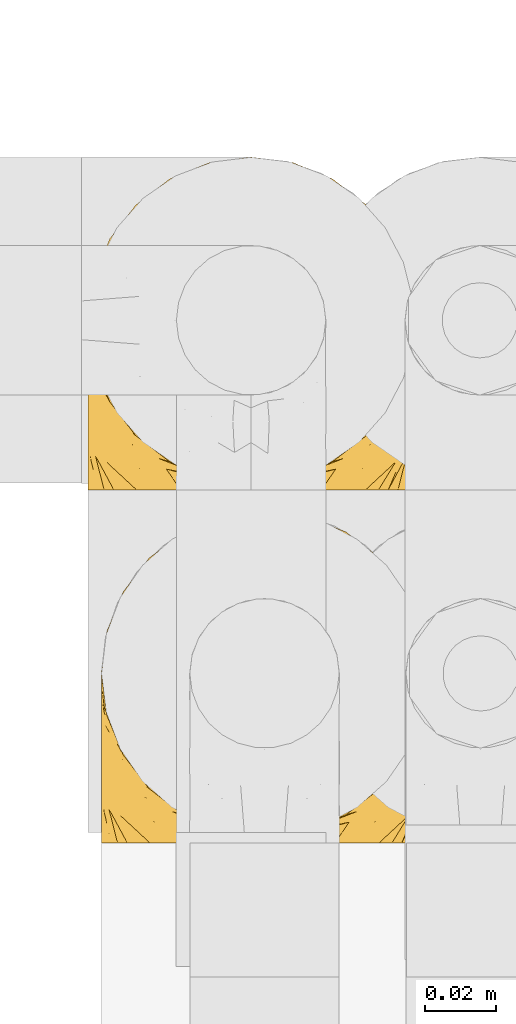
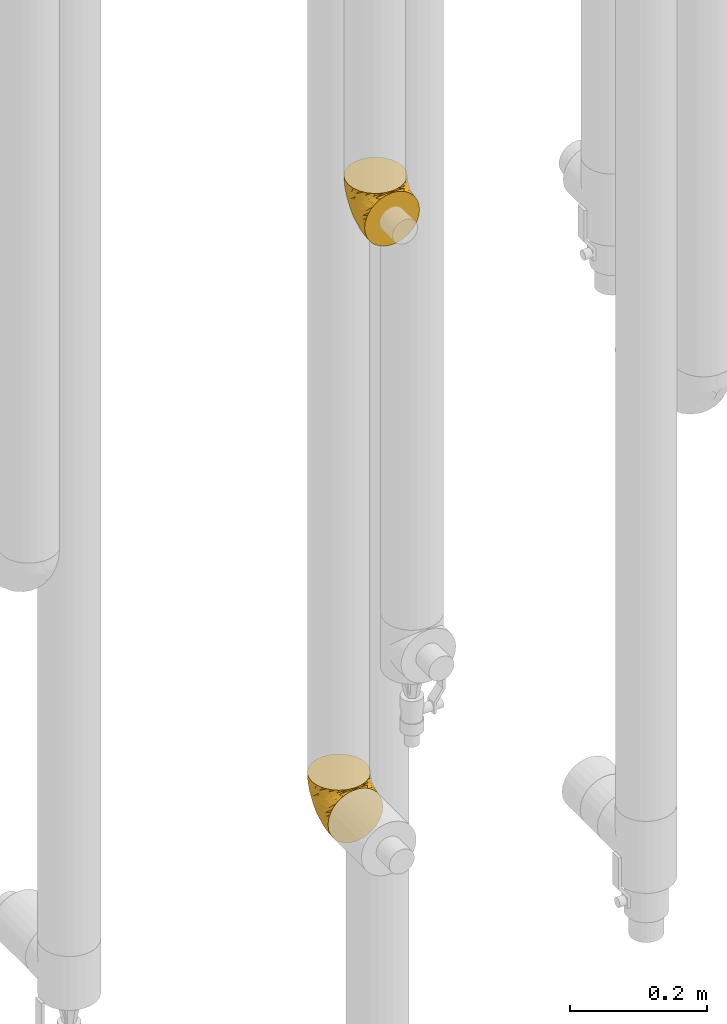
# One storey, part 240 of 827: 2 coverings.
"""IFC2X3 building model written with IfcOpenShell, lengths in millimetres."""

from ifc_helpers import new_model, entity, si_unit, converted_unit, derived_unit, direction, frame, origin, place, context, subcontext, project, spatial, faceted_brep, element, save


model = new_model("IFC2X3")

# Units and contexts
model_context = context("Model", 3, precision=0.01, world=origin(), true_north=direction((6.12303176911189e-17, 1.0)))
body_context = subcontext(model_context, "Body", "Model", "MODEL_VIEW")
ifc_project = project(units=[si_unit("LENGTHUNIT", "METRE", prefix="MILLI"), si_unit("AREAUNIT", "SQUARE_METRE"), si_unit("VOLUMEUNIT", "CUBIC_METRE"), converted_unit("PLANEANGLEUNIT", "DEGREE", entity("IfcRatioMeasure", 0.0174532925199433), si_unit("PLANEANGLEUNIT", "RADIAN"), dimensions=[0, 0, 0, 0, 0, 0, 0]), si_unit("MASSUNIT", "GRAM", prefix="KILO"), derived_unit("MASSDENSITYUNIT", [(si_unit("MASSUNIT", "GRAM", prefix="KILO"), 1), (si_unit("LENGTHUNIT", "METRE"), -3)]), derived_unit("MOMENTOFINERTIAUNIT", [(si_unit("LENGTHUNIT", "METRE"), 4)]), si_unit("TIMEUNIT", "SECOND"), si_unit("FREQUENCYUNIT", "HERTZ"), si_unit("THERMODYNAMICTEMPERATUREUNIT", "DEGREE_CELSIUS"), derived_unit("THERMALTRANSMITTANCEUNIT", [(si_unit("MASSUNIT", "GRAM", prefix="KILO"), 1), (si_unit("THERMODYNAMICTEMPERATUREUNIT", "KELVIN"), -1), (si_unit("TIMEUNIT", "SECOND"), -3)]), derived_unit("VOLUMETRICFLOWRATEUNIT", [(si_unit("LENGTHUNIT", "METRE"), 3), (si_unit("TIMEUNIT", "SECOND"), -1)]), derived_unit("MASSFLOWRATEUNIT", [(si_unit("MASSUNIT", "GRAM", prefix="KILO"), 1), (si_unit("TIMEUNIT", "SECOND"), -1)]), derived_unit("ROTATIONALFREQUENCYUNIT", [(si_unit("TIMEUNIT", "SECOND"), -1)]), si_unit("ELECTRICCURRENTUNIT", "AMPERE"), si_unit("ELECTRICVOLTAGEUNIT", "VOLT"), si_unit("POWERUNIT", "WATT"), si_unit("FORCEUNIT", "NEWTON", prefix="KILO"), si_unit("ILLUMINANCEUNIT", "LUX"), si_unit("LUMINOUSFLUXUNIT", "LUMEN"), si_unit("LUMINOUSINTENSITYUNIT", "CANDELA"), derived_unit("USERDEFINED", [(si_unit("MASSUNIT", "GRAM", prefix="KILO"), -1), (si_unit("LENGTHUNIT", "METRE"), -2), (si_unit("TIMEUNIT", "SECOND"), 3), (si_unit("LUMINOUSFLUXUNIT", "LUMEN"), 1)]), derived_unit("LINEARVELOCITYUNIT", [(si_unit("LENGTHUNIT", "METRE"), 1), (si_unit("TIMEUNIT", "SECOND"), -1)]), si_unit("PRESSUREUNIT", "PASCAL"), derived_unit("USERDEFINED", [(si_unit("LENGTHUNIT", "METRE"), -2), (si_unit("MASSUNIT", "GRAM", prefix="KILO"), 1), (si_unit("TIMEUNIT", "SECOND"), -2)]), derived_unit("LINEARFORCEUNIT", [(si_unit("MASSUNIT", "GRAM", prefix="KILO"), 1), (si_unit("LENGTHUNIT", "METRE"), 1), (si_unit("TIMEUNIT", "SECOND"), -2), (si_unit("LENGTHUNIT", "METRE"), -1)]), derived_unit("PLANARFORCEUNIT", [(si_unit("MASSUNIT", "GRAM", prefix="KILO"), 1), (si_unit("LENGTHUNIT", "METRE"), 1), (si_unit("TIMEUNIT", "SECOND"), -2), (si_unit("LENGTHUNIT", "METRE"), -2)])], contexts=[model_context])

# Site, building, storey
site_placement = place(None, origin())
site = spatial("IfcSite", under=ifc_project, at=site_placement, CompositionType="ELEMENT")
building_placement = place(site_placement, origin())
building = spatial("IfcBuilding", under=site, at=building_placement, CompositionType="ELEMENT")
storey_placement = place(building_placement, frame((0.0, 0.0, 28200.0)))
storey = spatial("IfcBuildingStorey", under=building, at=storey_placement, Name="08", CompositionType="ELEMENT", Elevation=28200.0)

# Coverings
covering_1_placement = place(storey_placement, frame((30622.54, 14866.61, 2202.65)))
element("IfcCovering", 1, at=covering_1_placement, inside=storey, Name=":ADSK_", ObjectType=":ADSK_", PredefinedType="INSULATION", context=body_context, shape_type="Brep", body=[
    faceted_brep([(11.68, 1.6, 18.98), (19.0, 1.6, 11.67), (27.76, 1.6, 6.17), (37.52, 1.6, 2.75), (47.8, 1.6, 1.6), (58.08, 1.6, 2.75), (67.85, 1.6, 6.17), (76.61, 1.6, 11.68), (83.92, 1.6, 19.0), (89.42, 1.6, 27.76), (92.84, 1.6, 37.52), (94.0, 1.6, 47.8), (93.53, 1.6, 51.94), (93.18, 1.6, 55.01), (92.84, 1.6, 58.08), (91.13, 1.6, 62.96), (89.42, 1.6, 67.85), (86.66, 1.6, 72.23), (83.91, 1.6, 76.61), (80.25, 1.6, 80.26), (76.59, 1.6, 83.92), (67.83, 1.6, 89.42), (62.95, 1.6, 91.13), (58.07, 1.6, 92.84), (47.8, 1.6, 94.0), (37.51, 1.6, 92.84), (32.63, 1.6, 91.13), (27.74, 1.6, 89.42), (18.98, 1.6, 83.91), (15.33, 1.6, 80.25), (11.67, 1.6, 76.59), (8.92, 1.6, 72.21), (6.17, 1.6, 67.83), (4.46, 1.6, 62.95), (2.75, 1.6, 58.07), (2.41, 1.6, 55.0), (2.06, 1.6, 51.94), (1.6, 1.6, 47.8), (2.75, 1.6, 37.51), (6.17, 1.6, 27.74), (47.8, 3.4, 95.8), (59.75, 4.97, 95.8), (70.9, 9.58, 95.8), (75.68, 13.26, 95.8), (80.46, 16.93, 95.8), (84.13, 21.71, 95.8), (87.81, 26.5, 95.8), (90.11, 32.07, 95.8), (92.42, 37.64, 95.8), (92.9, 41.25, 95.8), (93.17, 43.34, 95.8), (93.45, 45.42, 95.8), (94.0, 49.6, 95.8), (92.42, 61.55, 95.8), (87.81, 72.7, 95.8), (80.46, 82.26, 95.8), (70.9, 89.61, 95.8), (59.75, 94.22, 95.8), (47.8, 95.8, 95.8), (35.84, 94.22, 95.8), (24.7, 89.61, 95.8), (15.13, 82.26, 95.8), (7.78, 72.7, 95.8), (3.17, 61.55, 95.8), (1.6, 49.6, 95.8), (2.14, 45.42, 95.8), (2.69, 41.25, 95.8), (3.17, 37.64, 95.8), (5.48, 32.07, 95.8), (7.78, 26.5, 95.8), (11.46, 21.71, 95.8), (15.13, 16.93, 95.8), (19.91, 13.26, 95.8), (24.7, 9.58, 95.8), (35.84, 4.97, 95.8), (23.61, 81.55, 60.58), (31.99, 90.4, 74.11), (35.87, 83.0, 51.59), (47.8, 91.18, 66.69), (40.43, 93.13, 76.19), (47.8, 94.0, 84.43), (31.83, 66.19, 31.2), (23.37, 70.92, 42.88), (21.41, 85.95, 79.41), (3.07, 49.74, 60.7), (1.6, 35.54, 61.85), (1.6, 38.14, 65.75), (1.6, 40.74, 69.64), (1.6, 43.34, 73.53), (1.6, 45.94, 77.43), (13.45, 77.59, 74.59), (15.25, 71.17, 54.72), (8.07, 65.81, 64.18), (16.0, 59.03, 37.94), (17.34, 45.85, 25.89), (10.58, 45.79, 34.73), (5.34, 41.42, 42.89), (2.39, 34.51, 49.83), (8.36, 56.04, 48.58), (10.04, 15.15, 22.41), (2.59, 56.51, 78.69), (6.28, 68.39, 81.64), (34.28, 23.33, 6.22), (38.73, 42.86, 12.11), (27.25, 39.42, 14.81), (29.88, 53.58, 21.61), (38.6, 59.17, 22.41), (23.44, 59.06, 30.12), (25.25, 22.63, 10.01), (17.23, 20.55, 15.36), (47.8, 12.96, 3.39), (47.8, 56.96, 19.59), (47.8, 67.38, 30.01), (2.53, 18.72, 41.19), (1.6, 5.33, 48.54), (1.6, 9.07, 49.28), (1.6, 11.79, 49.82), (1.6, 14.51, 50.37), (1.6, 17.24, 50.91), (1.6, 19.96, 51.45), (5.71, 21.03, 31.61), (1.6, 46.48, 80.15), (1.6, 47.03, 82.88), (1.6, 47.57, 85.6), (1.6, 48.11, 88.32), (1.6, 48.48, 90.19), (1.6, 48.85, 92.06), (47.8, 30.7, 6.21), (1.6, 23.86, 54.05), (1.6, 27.75, 56.65), (1.6, 31.64, 59.25), (11.89, 31.26, 24.66), (47.8, 77.8, 40.43), (39.69, 72.75, 35.17), (47.8, 43.83, 12.9), (47.8, 84.49, 53.56), (13.84, 14.58, 85.34), (9.16, 16.17, 78.44), (15.79, 10.82, 84.37), (25.75, 4.64, 89.05), (16.09, 7.71, 82.76), (7.51, 25.13, 86.31), (3.99, 32.66, 83.73), (2.66, 34.94, 77.31), (3.16, 36.76, 87.78), (2.35, 40.48, 87.91), (2.23, 39.25, 81.29), (38.35, 3.69, 93.97), (6.18, 13.99, 70.76), (2.7, 21.85, 63.67), (2.93, 17.93, 62.62), (16.01, 15.11, 90.64), (9.08, 21.14, 84.08), (11.68, 7.21, 77.45), (6.83, 9.47, 70.34), (4.65, 32.27, 88.72), (3.65, 25.68, 71.28), (3.61, 22.18, 68.09), (12.8, 18.79, 91.07), (2.43, 10.12, 57.47), (21.65, 10.45, 91.35), (3.7, 11.29, 62.99), (47.8, 2.87, 94.52), (3.37, 31.16, 76.47), (9.3, 12.7, 76.28), (7.03, 6.31, 69.96), (7.87, 25.62, 89.86), (7.26, 21.18, 78.94), (3.41, 28.81, 73.51), (23.81, 7.45, 89.62), (86.5, 21.14, 84.09), (88.08, 25.13, 86.3), (82.79, 18.79, 91.06), (94.0, 48.11, 88.32), (94.0, 48.85, 92.06), (94.0, 47.03, 82.88), (94.0, 47.57, 85.6), (57.24, 3.69, 93.97), (71.76, 7.44, 89.63), (94.0, 14.51, 50.37), (94.0, 11.79, 49.82), (94.0, 5.33, 48.54), (94.0, 9.07, 49.28), (79.49, 7.71, 82.77), (88.75, 9.47, 70.36), (92.93, 34.94, 77.31), (92.22, 31.16, 76.47), (94.0, 40.74, 69.64), (94.0, 38.14, 65.75), (92.43, 36.76, 87.78), (93.24, 40.48, 87.91), (69.82, 4.63, 89.06), (79.57, 15.11, 90.65), (81.74, 14.58, 85.35), (94.0, 43.34, 73.53), (94.0, 45.94, 77.43), (93.36, 39.25, 81.29), (83.9, 7.21, 77.46), (86.28, 12.69, 76.29), (93.16, 10.14, 57.47), (92.88, 21.81, 63.71), (91.98, 22.19, 68.11), (89.41, 14.0, 70.77), (91.93, 25.69, 71.31), (86.42, 16.17, 78.46), (88.82, 6.66, 69.52), (92.66, 17.92, 62.64), (73.93, 10.45, 91.35), (94.0, 31.64, 59.25), (79.5, 10.64, 84.6), (91.89, 11.31, 62.98), (94.0, 19.96, 51.45), (94.0, 23.86, 54.05), (94.0, 27.75, 56.65), (91.6, 32.66, 83.73), (94.0, 46.48, 80.15), (90.94, 32.27, 88.72), (94.0, 35.54, 61.85), (92.16, 28.77, 73.56), (88.32, 21.17, 78.96), (86.13, 23.36, 91.36), (94.0, 17.24, 50.91), (93.2, 47.58, 62.87), (55.16, 93.13, 76.19), (82.02, 77.44, 73.57), (84.29, 66.78, 56.07), (76.94, 71.68, 49.77), (68.33, 74.96, 44.73), (71.98, 81.55, 60.58), (92.52, 36.7, 47.64), (92.9, 56.9, 78.32), (59.72, 83.0, 51.59), (63.6, 90.4, 74.11), (88.89, 67.83, 76.04), (74.18, 85.95, 79.41), (68.35, 39.41, 14.82), (61.33, 23.33, 6.22), (56.86, 42.87, 12.12), (68.62, 53.92, 23.51), (63.76, 66.19, 31.2), (72.19, 64.12, 34.96), (88.69, 33.13, 33.86), (92.19, 23.1, 38.94), (89.75, 16.98, 30.23), (59.86, 55.72, 20.67), (55.9, 72.75, 35.17), (77.99, 23.77, 15.85), (85.21, 18.41, 22.59), (74.99, 43.7, 21.56), (90.23, 54.53, 55.94), (70.75, 17.73, 9.19), (81.72, 38.98, 25.79), (86.53, 50.28, 41.16), (79.6, 59.02, 37.95)], [[[0, 1, 2, 3, 4, 5, 6, 7, 8, 9, 10, 11, 12, 13, 14, 15, 16, 17, 18, 19, 20, 21, 22, 23, 24, 25, 26, 27, 28, 29, 30, 31, 32, 33, 34, 35, 36, 37, 38, 39]], [[40, 41, 42, 43, 44, 45, 46, 47, 48, 49, 50, 51, 52, 53, 54, 55, 56, 57, 58, 59, 60, 61, 62, 63, 64, 65, 66, 67, 68, 69, 70, 71, 72, 73, 74]], [[75, 76, 77]], [[78, 79, 80]], [[77, 81, 82]], [[76, 75, 83]], [[84, 85, 86, 87, 88, 89]], [[90, 91, 92]], [[76, 60, 59]], [[93, 94, 95]], [[90, 62, 61]], [[83, 61, 60]], [[96, 97, 84]], [[98, 93, 95]], [[0, 39, 99]], [[100, 84, 89]], [[62, 101, 63]], [[2, 102, 3]], [[92, 84, 100]], [[103, 102, 104]], [[103, 105, 106]], [[93, 107, 94]], [[1, 108, 2]], [[92, 101, 90]], [[108, 1, 109]], [[102, 110, 3]], [[93, 82, 107]], [[102, 108, 104]], [[111, 106, 112]], [[109, 0, 99]], [[113, 37, 114, 115, 116, 117, 118, 119]], [[120, 38, 113]], [[100, 89, 121, 122, 123, 124, 125, 126, 64]], [[127, 102, 103]], [[97, 119, 128, 129, 130, 85]], [[99, 120, 131]], [[132, 133, 77]], [[59, 80, 79]], [[1, 0, 109]], [[98, 84, 92]], [[94, 109, 131]], [[120, 39, 38]], [[93, 91, 82]], [[104, 94, 105]], [[97, 113, 119]], [[95, 120, 96]], [[83, 90, 61]], [[91, 93, 98]], [[64, 63, 100]], [[100, 63, 101]], [[77, 76, 79]], [[133, 106, 81]], [[84, 97, 85]], [[113, 96, 120]], [[113, 97, 96]], [[37, 113, 38]], [[110, 102, 127]], [[110, 4, 3]], [[103, 111, 134, 127]], [[90, 75, 91]], [[82, 81, 107]], [[91, 75, 82]], [[77, 82, 75]], [[76, 83, 60]], [[90, 83, 75]], [[105, 107, 81]], [[94, 131, 95]], [[105, 94, 107]], [[109, 94, 104]], [[120, 95, 131]], [[98, 95, 96]], [[84, 98, 96]], [[98, 92, 91]], [[106, 105, 81]], [[103, 104, 105]], [[112, 106, 133]], [[103, 106, 111]], [[112, 133, 132]], [[81, 77, 133]], [[77, 78, 135, 132]], [[120, 99, 39]], [[109, 99, 131]], [[59, 58, 80]], [[59, 79, 76]], [[90, 101, 62]], [[100, 101, 92]], [[2, 108, 102]], [[109, 104, 108]], [[78, 77, 79]], [[136, 137, 138]], [[27, 139, 140]], [[141, 142, 143]], [[144, 145, 121]], [[146, 89, 88]], [[147, 139, 25]], [[148, 149, 150]], [[136, 151, 152]], [[147, 40, 74]], [[24, 147, 25]], [[153, 148, 154]], [[33, 116, 34]], [[73, 72, 151]], [[114, 37, 36, 35, 34, 116, 115]], [[146, 155, 144]], [[156, 85, 130]], [[157, 149, 148]], [[151, 158, 152]], [[117, 33, 159]], [[29, 153, 154]], [[160, 74, 73]], [[161, 128, 119]], [[66, 65, 64, 126, 125, 124, 123, 122, 67]], [[162, 147, 24]], [[27, 140, 28]], [[149, 129, 150]], [[139, 27, 26, 25]], [[68, 144, 69]], [[129, 128, 150]], [[163, 87, 86]], [[130, 129, 149]], [[122, 145, 67]], [[153, 164, 148]], [[161, 119, 159]], [[165, 30, 154]], [[150, 154, 148]], [[128, 161, 150]], [[30, 165, 31]], [[145, 144, 68]], [[89, 146, 144]], [[87, 163, 143]], [[166, 155, 142]], [[88, 87, 143]], [[161, 154, 150]], [[154, 30, 29]], [[29, 28, 153]], [[28, 140, 153]], [[164, 153, 140]], [[140, 137, 164]], [[157, 148, 164]], [[156, 130, 157]], [[164, 137, 157]], [[157, 137, 156]], [[167, 137, 136]], [[168, 85, 156]], [[152, 168, 167]], [[167, 168, 156]], [[163, 152, 141]], [[71, 158, 72]], [[152, 167, 136]], [[88, 142, 146]], [[144, 155, 69]], [[146, 142, 155]], [[70, 166, 71]], [[142, 141, 166]], [[70, 69, 155]], [[141, 158, 71]], [[160, 73, 151]], [[138, 137, 140]], [[160, 136, 169]], [[136, 160, 151]], [[74, 160, 169]], [[152, 158, 141]], [[151, 72, 158]], [[168, 152, 163]], [[137, 167, 156]], [[163, 86, 168]], [[85, 168, 86]], [[116, 33, 117]], [[130, 149, 157]], [[67, 145, 68]], [[121, 89, 144]], [[145, 122, 121]], [[40, 147, 162]], [[169, 147, 74]], [[159, 33, 32]], [[161, 159, 32]], [[159, 119, 118, 117]], [[139, 147, 169]], [[139, 169, 138]], [[161, 32, 31]], [[141, 143, 163]], [[88, 143, 142]], [[71, 166, 141]], [[155, 166, 70]], [[139, 138, 140]], [[169, 136, 138]], [[154, 161, 165]], [[161, 31, 165]], [[170, 171, 172]], [[173, 174, 52, 51, 50, 49, 48, 175, 176]], [[177, 178, 41]], [[179, 15, 180]], [[12, 11, 181, 182, 180, 14, 13]], [[183, 21, 20]], [[19, 18, 184]], [[185, 186, 187]], [[186, 188, 187]], [[43, 172, 44]], [[189, 190, 47]], [[23, 22, 21, 191]], [[170, 192, 193]], [[40, 162, 177]], [[194, 195, 196]], [[24, 23, 177]], [[197, 198, 183]], [[199, 15, 179]], [[47, 46, 189]], [[200, 201, 202]], [[201, 203, 204]], [[205, 206, 184]], [[207, 41, 178]], [[16, 15, 199]], [[14, 180, 15]], [[202, 201, 198]], [[208, 201, 200]], [[162, 24, 177]], [[48, 47, 190]], [[196, 195, 189]], [[197, 184, 202]], [[204, 193, 209]], [[210, 211, 212]], [[206, 212, 213]], [[205, 17, 210]], [[184, 206, 202]], [[210, 212, 206]], [[185, 194, 214]], [[189, 215, 190]], [[216, 45, 214]], [[186, 171, 170]], [[189, 216, 196]], [[197, 20, 19]], [[194, 185, 187]], [[197, 183, 20]], [[184, 197, 19]], [[197, 202, 198]], [[206, 200, 202]], [[204, 183, 198]], [[201, 208, 203]], [[203, 208, 217]], [[204, 198, 201]], [[217, 188, 218]], [[193, 219, 170]], [[171, 186, 185]], [[170, 218, 186]], [[170, 219, 218]], [[42, 207, 192]], [[171, 220, 172]], [[216, 189, 46]], [[214, 194, 196]], [[44, 220, 45]], [[214, 196, 216]], [[216, 46, 45]], [[214, 45, 220]], [[192, 43, 42]], [[204, 203, 219]], [[207, 193, 192]], [[209, 193, 178]], [[41, 207, 42]], [[193, 207, 178]], [[43, 192, 172]], [[170, 172, 192]], [[204, 219, 193]], [[219, 203, 218]], [[217, 218, 203]], [[188, 186, 218]], [[206, 213, 200]], [[208, 200, 213]], [[199, 210, 16]], [[215, 189, 195]], [[215, 175, 190]], [[175, 48, 190]], [[199, 179, 221, 211]], [[210, 199, 211]], [[23, 191, 177]], [[40, 177, 41]], [[183, 209, 191]], [[183, 191, 21]], [[191, 178, 177]], [[205, 18, 17]], [[17, 16, 210]], [[171, 185, 214]], [[172, 220, 44]], [[214, 220, 171]], [[191, 209, 178]], [[204, 209, 183]], [[206, 205, 210]], [[18, 205, 184]], [[222, 195, 194, 187, 188, 217]], [[57, 223, 80]], [[224, 225, 226]], [[226, 227, 228]], [[229, 217, 208, 213, 212, 211]], [[230, 52, 174, 173, 176, 175, 215, 195]], [[231, 232, 228]], [[231, 78, 223]], [[223, 57, 232]], [[224, 233, 225]], [[233, 54, 53]], [[234, 232, 56]], [[56, 55, 234]], [[234, 224, 228]], [[235, 236, 237]], [[224, 55, 54]], [[238, 239, 240]], [[52, 230, 53]], [[241, 242, 243]], [[239, 244, 245]], [[11, 10, 242]], [[236, 6, 5]], [[7, 246, 8]], [[8, 247, 9]], [[238, 248, 235]], [[222, 229, 249]], [[242, 211, 221, 179, 180, 182, 181, 11]], [[233, 53, 230]], [[111, 112, 244]], [[250, 6, 236]], [[247, 251, 241]], [[6, 250, 7]], [[127, 236, 110]], [[249, 229, 252]], [[247, 8, 246]], [[235, 246, 250]], [[236, 5, 110]], [[235, 244, 238]], [[237, 236, 127]], [[243, 9, 247]], [[252, 229, 241]], [[56, 232, 57]], [[222, 230, 195]], [[225, 249, 252]], [[249, 233, 230]], [[54, 233, 224]], [[231, 228, 227]], [[245, 132, 231]], [[249, 225, 233]], [[226, 225, 253]], [[235, 250, 236]], [[246, 7, 250]], [[251, 247, 246]], [[243, 247, 241]], [[248, 246, 235]], [[252, 251, 253]], [[229, 222, 217]], [[230, 222, 249]], [[5, 4, 110]], [[237, 127, 134, 111]], [[238, 244, 239]], [[224, 234, 55]], [[232, 234, 228]], [[242, 241, 229]], [[10, 9, 243]], [[211, 242, 229]], [[10, 243, 242]], [[80, 223, 78]], [[80, 58, 57]], [[231, 223, 232]], [[227, 240, 239]], [[224, 226, 228]], [[240, 226, 253]], [[227, 239, 245]], [[226, 240, 227]], [[251, 248, 253]], [[240, 253, 248]], [[244, 235, 237]], [[237, 111, 244]], [[132, 245, 112]], [[112, 245, 244]], [[135, 78, 231, 132]], [[227, 245, 231]], [[248, 238, 240]], [[246, 248, 251]], [[251, 252, 241]], [[225, 252, 253]]]),
])
covering_2_placement = place(storey_placement, frame((30618.73, 14966.61, 1082.65)))
element("IfcCovering", 2, at=covering_2_placement, inside=storey, Name=":ADSK_", ObjectType=":ADSK_", PredefinedType="INSULATION", context=body_context, shape_type="Brep", body=[
    faceted_brep([(11.68, 1.6, 18.98), (19.0, 1.6, 11.67), (27.76, 1.6, 6.17), (37.52, 1.6, 2.75), (47.8, 1.6, 1.6), (58.08, 1.6, 2.75), (67.85, 1.6, 6.17), (76.61, 1.6, 11.68), (83.92, 1.6, 19.0), (89.42, 1.6, 27.76), (92.84, 1.6, 37.52), (94.0, 1.6, 47.8), (93.53, 1.6, 51.94), (93.18, 1.6, 55.01), (92.84, 1.6, 58.08), (91.13, 1.6, 62.96), (89.42, 1.6, 67.85), (86.66, 1.6, 72.23), (83.91, 1.6, 76.61), (80.25, 1.6, 80.26), (76.59, 1.6, 83.92), (67.83, 1.6, 89.42), (62.95, 1.6, 91.13), (58.07, 1.6, 92.84), (47.8, 1.6, 94.0), (37.51, 1.6, 92.84), (32.63, 1.6, 91.13), (27.74, 1.6, 89.42), (18.98, 1.6, 83.91), (15.33, 1.6, 80.25), (11.67, 1.6, 76.59), (8.92, 1.6, 72.21), (6.17, 1.6, 67.83), (4.46, 1.6, 62.95), (2.75, 1.6, 58.07), (2.41, 1.6, 55.0), (2.06, 1.6, 51.94), (1.6, 1.6, 47.8), (2.75, 1.6, 37.51), (6.17, 1.6, 27.74), (47.8, 3.4, 95.8), (59.75, 4.97, 95.8), (70.9, 9.58, 95.8), (75.68, 13.26, 95.8), (80.46, 16.93, 95.8), (84.13, 21.71, 95.8), (87.81, 26.5, 95.8), (90.11, 32.07, 95.8), (92.42, 37.64, 95.8), (92.9, 41.25, 95.8), (93.17, 43.34, 95.8), (93.45, 45.42, 95.8), (94.0, 49.6, 95.8), (92.42, 61.55, 95.8), (87.81, 72.7, 95.8), (80.46, 82.26, 95.8), (70.9, 89.61, 95.8), (59.75, 94.22, 95.8), (47.8, 95.8, 95.8), (35.84, 94.22, 95.8), (24.7, 89.61, 95.8), (15.13, 82.26, 95.8), (7.78, 72.7, 95.8), (3.17, 61.55, 95.8), (1.6, 49.6, 95.8), (2.14, 45.42, 95.8), (2.69, 41.25, 95.8), (3.17, 37.64, 95.8), (5.48, 32.07, 95.8), (7.78, 26.5, 95.8), (11.46, 21.71, 95.8), (15.13, 16.93, 95.8), (19.91, 13.26, 95.8), (24.7, 9.58, 95.8), (35.84, 4.97, 95.8), (23.61, 81.55, 60.58), (31.99, 90.4, 74.11), (35.87, 83.0, 51.59), (47.8, 91.18, 66.69), (40.43, 93.13, 76.19), (47.8, 94.0, 84.43), (31.83, 66.19, 31.2), (23.37, 70.92, 42.88), (21.41, 85.95, 79.41), (3.07, 49.74, 60.7), (1.6, 35.54, 61.85), (1.6, 38.14, 65.75), (1.6, 40.74, 69.64), (1.6, 43.34, 73.53), (1.6, 45.94, 77.43), (13.45, 77.59, 74.59), (15.25, 71.17, 54.72), (8.07, 65.81, 64.18), (16.0, 59.03, 37.94), (17.34, 45.85, 25.89), (10.58, 45.79, 34.73), (5.34, 41.42, 42.89), (2.39, 34.51, 49.83), (8.36, 56.04, 48.58), (10.04, 15.15, 22.41), (2.59, 56.51, 78.69), (6.28, 68.39, 81.64), (34.28, 23.33, 6.22), (38.73, 42.86, 12.11), (27.25, 39.42, 14.81), (29.88, 53.58, 21.61), (38.6, 59.17, 22.41), (23.44, 59.06, 30.12), (25.25, 22.63, 10.01), (17.23, 20.55, 15.36), (47.8, 12.96, 3.39), (47.8, 56.96, 19.59), (47.8, 67.38, 30.01), (2.53, 18.72, 41.19), (1.6, 5.33, 48.54), (1.6, 9.07, 49.28), (1.6, 11.79, 49.82), (1.6, 14.51, 50.37), (1.6, 17.24, 50.91), (1.6, 19.96, 51.45), (5.71, 21.03, 31.61), (1.6, 46.48, 80.15), (1.6, 47.03, 82.88), (1.6, 47.57, 85.6), (1.6, 48.11, 88.32), (1.6, 48.48, 90.19), (1.6, 48.85, 92.06), (47.8, 30.7, 6.21), (1.6, 23.86, 54.05), (1.6, 27.75, 56.65), (1.6, 31.64, 59.25), (11.89, 31.26, 24.66), (47.8, 77.8, 40.43), (39.69, 72.75, 35.17), (47.8, 43.83, 12.9), (47.8, 84.49, 53.56), (13.84, 14.58, 85.34), (9.16, 16.17, 78.44), (15.79, 10.82, 84.37), (25.75, 4.64, 89.05), (16.09, 7.71, 82.76), (7.51, 25.13, 86.31), (3.99, 32.66, 83.73), (2.66, 34.94, 77.31), (3.16, 36.76, 87.78), (2.35, 40.48, 87.91), (2.23, 39.25, 81.29), (38.35, 3.69, 93.97), (6.18, 13.99, 70.76), (2.7, 21.85, 63.67), (2.93, 17.93, 62.62), (16.01, 15.11, 90.64), (9.08, 21.14, 84.08), (11.68, 7.21, 77.45), (6.83, 9.47, 70.34), (4.65, 32.27, 88.72), (3.65, 25.68, 71.28), (3.61, 22.18, 68.09), (12.8, 18.79, 91.07), (2.43, 10.12, 57.47), (21.65, 10.45, 91.35), (3.7, 11.29, 62.99), (47.8, 2.87, 94.52), (3.37, 31.16, 76.47), (9.3, 12.7, 76.28), (7.03, 6.31, 69.96), (7.87, 25.62, 89.86), (7.26, 21.18, 78.94), (3.41, 28.81, 73.51), (23.81, 7.45, 89.62), (86.5, 21.14, 84.09), (88.08, 25.13, 86.3), (82.79, 18.79, 91.06), (94.0, 48.85, 92.06), (94.0, 47.03, 82.88), (94.0, 47.57, 85.6), (94.0, 48.11, 88.32), (57.24, 3.69, 93.97), (71.76, 7.44, 89.63), (94.0, 14.51, 50.37), (94.0, 11.79, 49.82), (94.0, 5.33, 48.54), (94.0, 9.07, 49.28), (79.49, 7.71, 82.77), (88.75, 9.47, 70.36), (92.93, 34.94, 77.31), (92.22, 31.16, 76.47), (94.0, 40.74, 69.64), (94.0, 38.14, 65.75), (92.43, 36.76, 87.78), (93.24, 40.48, 87.91), (69.82, 4.63, 89.06), (79.57, 15.11, 90.65), (81.74, 14.58, 85.35), (94.0, 43.34, 73.53), (94.0, 45.94, 77.43), (93.36, 39.25, 81.29), (83.9, 7.21, 77.46), (86.28, 12.69, 76.29), (93.16, 10.14, 57.47), (92.88, 21.81, 63.71), (91.98, 22.19, 68.11), (89.41, 14.0, 70.77), (91.93, 25.69, 71.31), (86.42, 16.17, 78.46), (88.82, 6.66, 69.52), (92.66, 17.92, 62.64), (73.93, 10.45, 91.35), (94.0, 31.64, 59.25), (79.5, 10.64, 84.6), (91.89, 11.31, 62.98), (94.0, 19.96, 51.45), (94.0, 23.86, 54.05), (94.0, 27.75, 56.65), (91.6, 32.66, 83.73), (94.0, 46.48, 80.15), (90.94, 32.27, 88.72), (94.0, 35.54, 61.85), (92.16, 28.77, 73.56), (88.32, 21.17, 78.96), (86.13, 23.36, 91.36), (94.0, 17.24, 50.91), (93.2, 47.58, 62.87), (55.16, 93.13, 76.19), (82.02, 77.44, 73.57), (84.29, 66.78, 56.07), (76.94, 71.68, 49.77), (68.33, 74.96, 44.73), (71.98, 81.55, 60.58), (92.52, 36.7, 47.64), (92.9, 56.9, 78.32), (59.72, 83.0, 51.59), (63.6, 90.4, 74.11), (88.89, 67.83, 76.04), (74.18, 85.95, 79.41), (68.35, 39.41, 14.82), (61.33, 23.33, 6.22), (56.86, 42.87, 12.12), (68.62, 53.92, 23.51), (63.76, 66.19, 31.2), (72.19, 64.12, 34.96), (88.69, 33.13, 33.86), (92.19, 23.1, 38.94), (89.75, 16.98, 30.23), (59.86, 55.72, 20.67), (55.9, 72.75, 35.17), (77.99, 23.77, 15.85), (85.21, 18.41, 22.59), (74.99, 43.7, 21.56), (90.23, 54.53, 55.94), (70.75, 17.73, 9.19), (81.72, 38.98, 25.79), (86.53, 50.28, 41.16), (79.6, 59.02, 37.95)], [[[0, 1, 2, 3, 4, 5, 6, 7, 8, 9, 10, 11, 12, 13, 14, 15, 16, 17, 18, 19, 20, 21, 22, 23, 24, 25, 26, 27, 28, 29, 30, 31, 32, 33, 34, 35, 36, 37, 38, 39]], [[40, 41, 42, 43, 44, 45, 46, 47, 48, 49, 50, 51, 52, 53, 54, 55, 56, 57, 58, 59, 60, 61, 62, 63, 64, 65, 66, 67, 68, 69, 70, 71, 72, 73, 74]], [[75, 76, 77]], [[78, 79, 80]], [[77, 81, 82]], [[76, 75, 83]], [[84, 85, 86, 87, 88, 89]], [[90, 91, 92]], [[76, 60, 59]], [[93, 94, 95]], [[90, 62, 61]], [[83, 61, 60]], [[96, 97, 84]], [[98, 93, 95]], [[0, 39, 99]], [[100, 84, 89]], [[62, 101, 63]], [[2, 102, 3]], [[92, 84, 100]], [[103, 102, 104]], [[103, 105, 106]], [[93, 107, 94]], [[1, 108, 2]], [[92, 101, 90]], [[108, 1, 109]], [[102, 110, 3]], [[93, 82, 107]], [[102, 108, 104]], [[111, 106, 112]], [[109, 0, 99]], [[113, 37, 114, 115, 116, 117, 118, 119]], [[120, 38, 113]], [[100, 89, 121, 122, 123, 124, 125, 126, 64]], [[127, 102, 103]], [[97, 119, 128, 129, 130, 85]], [[99, 120, 131]], [[132, 133, 77]], [[59, 80, 79]], [[1, 0, 109]], [[98, 84, 92]], [[94, 109, 131]], [[120, 39, 38]], [[93, 91, 82]], [[104, 94, 105]], [[97, 113, 119]], [[95, 120, 96]], [[83, 90, 61]], [[91, 93, 98]], [[64, 63, 100]], [[100, 63, 101]], [[77, 76, 79]], [[133, 106, 81]], [[84, 97, 85]], [[113, 96, 120]], [[113, 97, 96]], [[37, 113, 38]], [[110, 102, 127]], [[110, 4, 3]], [[103, 111, 134, 127]], [[90, 75, 91]], [[82, 81, 107]], [[91, 75, 82]], [[77, 82, 75]], [[76, 83, 60]], [[90, 83, 75]], [[105, 107, 81]], [[94, 131, 95]], [[105, 94, 107]], [[109, 94, 104]], [[120, 95, 131]], [[98, 95, 96]], [[84, 98, 96]], [[98, 92, 91]], [[106, 105, 81]], [[103, 104, 105]], [[133, 132, 112]], [[103, 106, 111]], [[77, 78, 135, 132]], [[81, 77, 133]], [[106, 133, 112]], [[120, 99, 39]], [[109, 99, 131]], [[59, 58, 80]], [[59, 79, 76]], [[90, 101, 62]], [[100, 101, 92]], [[2, 108, 102]], [[109, 104, 108]], [[78, 77, 79]], [[136, 137, 138]], [[27, 139, 140]], [[141, 142, 143]], [[144, 145, 121]], [[146, 89, 88]], [[147, 139, 25]], [[148, 149, 150]], [[136, 151, 152]], [[147, 40, 74]], [[24, 147, 25]], [[153, 148, 154]], [[33, 116, 34]], [[73, 72, 151]], [[114, 37, 36, 35, 34, 116, 115]], [[146, 155, 144]], [[156, 85, 130]], [[157, 149, 148]], [[151, 158, 152]], [[117, 33, 159]], [[29, 153, 154]], [[160, 74, 73]], [[161, 128, 119]], [[66, 65, 64, 126, 125, 124, 123, 122, 67]], [[162, 147, 24]], [[27, 140, 28]], [[149, 129, 150]], [[139, 27, 26, 25]], [[68, 144, 69]], [[129, 128, 150]], [[163, 87, 86]], [[130, 129, 149]], [[122, 145, 67]], [[153, 164, 148]], [[161, 119, 159]], [[165, 30, 154]], [[150, 154, 148]], [[128, 161, 150]], [[30, 165, 31]], [[145, 144, 68]], [[89, 146, 144]], [[87, 163, 143]], [[166, 155, 142]], [[88, 87, 143]], [[161, 154, 150]], [[154, 30, 29]], [[29, 28, 153]], [[28, 140, 153]], [[164, 153, 140]], [[140, 137, 164]], [[157, 148, 164]], [[156, 130, 157]], [[164, 137, 157]], [[157, 137, 156]], [[167, 137, 136]], [[168, 85, 156]], [[152, 168, 167]], [[167, 168, 156]], [[163, 152, 141]], [[71, 158, 72]], [[152, 167, 136]], [[88, 142, 146]], [[144, 155, 69]], [[146, 142, 155]], [[70, 166, 71]], [[142, 141, 166]], [[70, 69, 155]], [[141, 158, 71]], [[160, 73, 151]], [[138, 137, 140]], [[160, 136, 169]], [[136, 160, 151]], [[74, 160, 169]], [[152, 158, 141]], [[151, 72, 158]], [[168, 152, 163]], [[137, 167, 156]], [[163, 86, 168]], [[85, 168, 86]], [[116, 33, 117]], [[130, 149, 157]], [[67, 145, 68]], [[121, 89, 144]], [[145, 122, 121]], [[40, 147, 162]], [[169, 147, 74]], [[159, 33, 32]], [[161, 159, 32]], [[159, 119, 118, 117]], [[139, 147, 169]], [[139, 169, 138]], [[161, 32, 31]], [[141, 143, 163]], [[88, 143, 142]], [[71, 166, 141]], [[155, 166, 70]], [[139, 138, 140]], [[169, 136, 138]], [[154, 161, 165]], [[161, 31, 165]], [[170, 171, 172]], [[173, 52, 51, 50, 49, 48, 174, 175, 176]], [[177, 178, 41]], [[179, 15, 180]], [[12, 11, 181, 182, 180, 14, 13]], [[183, 21, 20]], [[19, 18, 184]], [[185, 186, 187]], [[186, 188, 187]], [[43, 172, 44]], [[189, 190, 47]], [[23, 22, 21, 191]], [[170, 192, 193]], [[40, 162, 177]], [[194, 195, 196]], [[24, 23, 177]], [[197, 198, 183]], [[199, 15, 179]], [[47, 46, 189]], [[200, 201, 202]], [[201, 203, 204]], [[205, 206, 184]], [[207, 41, 178]], [[16, 15, 199]], [[14, 180, 15]], [[202, 201, 198]], [[208, 201, 200]], [[162, 24, 177]], [[48, 47, 190]], [[196, 195, 189]], [[197, 184, 202]], [[204, 193, 209]], [[210, 211, 212]], [[206, 212, 213]], [[205, 17, 210]], [[184, 206, 202]], [[210, 212, 206]], [[185, 194, 214]], [[189, 215, 190]], [[216, 45, 214]], [[186, 171, 170]], [[189, 216, 196]], [[197, 20, 19]], [[194, 185, 187]], [[197, 183, 20]], [[184, 197, 19]], [[197, 202, 198]], [[206, 200, 202]], [[204, 183, 198]], [[201, 208, 203]], [[203, 208, 217]], [[204, 198, 201]], [[217, 188, 218]], [[193, 219, 170]], [[171, 186, 185]], [[170, 218, 186]], [[170, 219, 218]], [[42, 207, 192]], [[171, 220, 172]], [[216, 189, 46]], [[214, 194, 196]], [[44, 220, 45]], [[214, 196, 216]], [[216, 46, 45]], [[214, 45, 220]], [[192, 43, 42]], [[204, 203, 219]], [[207, 193, 192]], [[209, 193, 178]], [[41, 207, 42]], [[193, 207, 178]], [[43, 192, 172]], [[170, 172, 192]], [[204, 219, 193]], [[219, 203, 218]], [[217, 218, 203]], [[188, 186, 218]], [[206, 213, 200]], [[208, 200, 213]], [[199, 210, 16]], [[215, 189, 195]], [[215, 174, 190]], [[174, 48, 190]], [[199, 179, 221, 211]], [[210, 199, 211]], [[23, 191, 177]], [[40, 177, 41]], [[183, 209, 191]], [[183, 191, 21]], [[191, 178, 177]], [[205, 18, 17]], [[17, 16, 210]], [[171, 185, 214]], [[172, 220, 44]], [[214, 220, 171]], [[191, 209, 178]], [[204, 209, 183]], [[206, 205, 210]], [[18, 205, 184]], [[222, 195, 194, 187, 188, 217]], [[57, 223, 80]], [[224, 225, 226]], [[226, 227, 228]], [[229, 217, 208, 213, 212, 211]], [[230, 52, 173, 176, 175, 174, 215, 195]], [[231, 232, 228]], [[231, 78, 223]], [[223, 57, 232]], [[224, 233, 225]], [[233, 54, 53]], [[234, 232, 56]], [[56, 55, 234]], [[234, 224, 228]], [[235, 236, 237]], [[224, 55, 54]], [[238, 239, 240]], [[52, 230, 53]], [[241, 242, 243]], [[239, 244, 245]], [[11, 10, 242]], [[236, 6, 5]], [[7, 246, 8]], [[8, 247, 9]], [[238, 248, 235]], [[222, 229, 249]], [[242, 211, 221, 179, 180, 182, 181, 11]], [[233, 53, 230]], [[111, 112, 244]], [[250, 6, 236]], [[247, 251, 241]], [[6, 250, 7]], [[127, 236, 110]], [[249, 229, 252]], [[247, 8, 246]], [[235, 246, 250]], [[236, 5, 110]], [[235, 244, 238]], [[237, 236, 127]], [[243, 9, 247]], [[252, 229, 241]], [[56, 232, 57]], [[222, 230, 195]], [[225, 249, 252]], [[249, 233, 230]], [[54, 233, 224]], [[231, 228, 227]], [[245, 132, 231]], [[249, 225, 233]], [[226, 225, 253]], [[235, 250, 236]], [[246, 7, 250]], [[251, 247, 246]], [[243, 247, 241]], [[248, 246, 235]], [[252, 251, 253]], [[229, 222, 217]], [[230, 222, 249]], [[5, 4, 110]], [[237, 127, 134, 111]], [[238, 244, 239]], [[224, 234, 55]], [[232, 234, 228]], [[242, 241, 229]], [[10, 9, 243]], [[211, 242, 229]], [[10, 243, 242]], [[80, 223, 78]], [[80, 58, 57]], [[231, 223, 232]], [[227, 240, 239]], [[224, 226, 228]], [[240, 226, 253]], [[227, 239, 245]], [[226, 240, 227]], [[251, 248, 253]], [[240, 253, 248]], [[244, 235, 237]], [[237, 111, 244]], [[132, 245, 112]], [[112, 245, 244]], [[135, 78, 231, 132]], [[227, 245, 231]], [[248, 238, 240]], [[246, 248, 251]], [[251, 252, 241]], [[225, 252, 253]]]),
])

save(model, "model.ifc")
